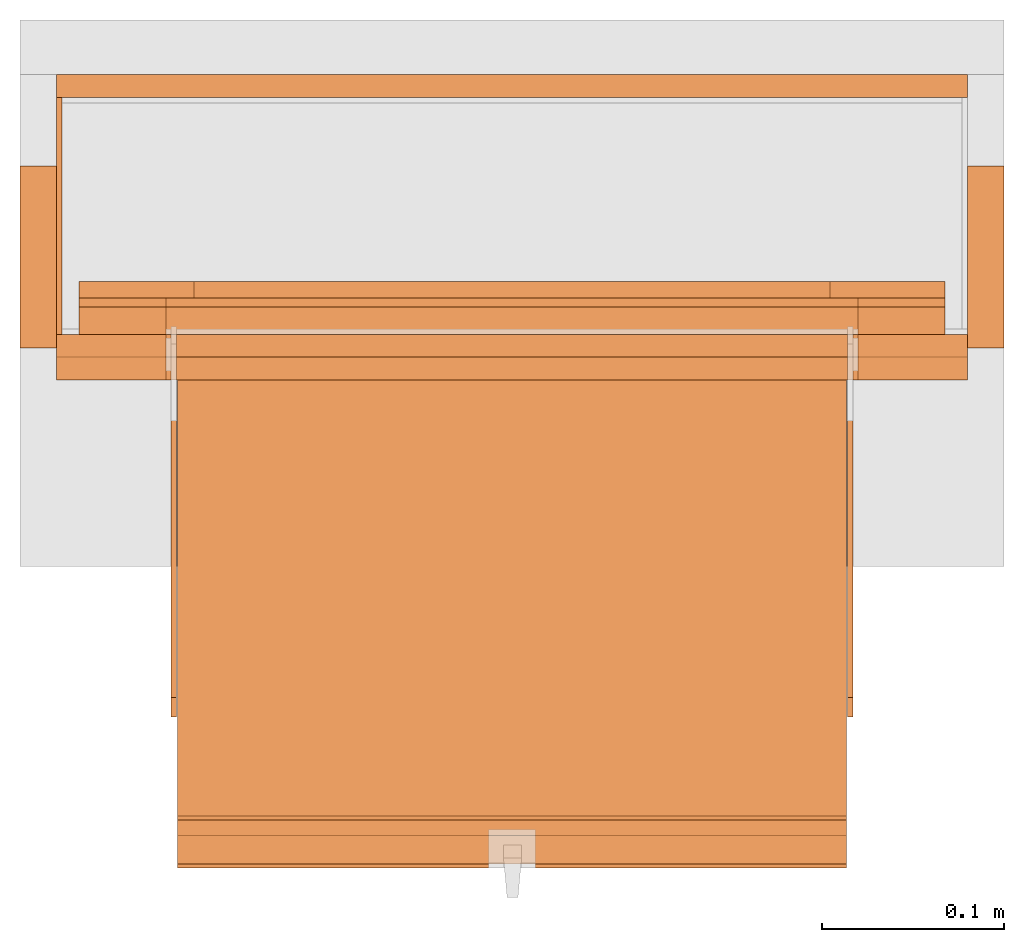
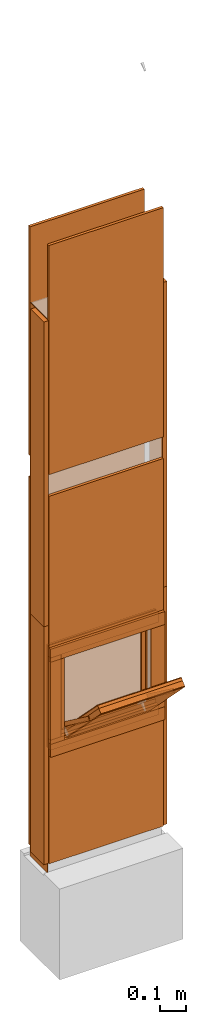
# One storey, part 1 of 4: 32 proxies, 1 opening.
"""IFC2X3 building model written with IfcOpenShell, lengths in metres."""

from ifc_helpers import new_model, entity, si_unit, converted_unit, derived_unit, money_unit, direction, frame, origin_with_axes, origin_2d_with_axis, place, context, subcontext, project, spatial, polyline, rectangle, outline, extrude, faceted_brep, source, transform, mapped, material, type_object, element, save


model = new_model("IFC2X3")

# Units and contexts
model_context = context("Model", 3, precision=1e-05, world=origin_with_axes(), true_north=direction((0.0, 1.0)))
plan_context = context("Plan", 3, precision=1e-05, world=origin_with_axes(), true_north=direction((0.0, 1.0)))
body_context = subcontext(model_context, "Body", "Model", "MODEL_VIEW")
ifc_project = project(units=[si_unit("LENGTHUNIT", "METRE"), si_unit("AREAUNIT", "SQUARE_METRE"), si_unit("VOLUMEUNIT", "CUBIC_METRE"), converted_unit("PLANEANGLEUNIT", "DEGREE", entity("IfcPlaneAngleMeasure", 0.0174532925199), si_unit("PLANEANGLEUNIT", "RADIAN"), dimensions=[0, 0, 0, 0, 0, 0, 0]), si_unit("SOLIDANGLEUNIT", "STERADIAN"), money_unit("CHF"), converted_unit("TIMEUNIT", "Year", entity("IfcTimeMeasure", 31556926.0), si_unit("TIMEUNIT", "SECOND"), dimensions=[0, 0, 1, 0, 0, 0, 0]), si_unit("MASSUNIT", "GRAM", prefix="KILO"), si_unit("THERMODYNAMICTEMPERATUREUNIT", "DEGREE_CELSIUS"), si_unit("LUMINOUSINTENSITYUNIT", "LUMEN"), si_unit("ENERGYUNIT", "JOULE", prefix="MEGA"), derived_unit("THERMALCONDUCTANCEUNIT", [(si_unit("POWERUNIT", "WATT"), 1), (si_unit("LENGTHUNIT", "METRE"), -1), (si_unit("THERMODYNAMICTEMPERATUREUNIT", "KELVIN"), -1)]), derived_unit("SPECIFICHEATCAPACITYUNIT", [(si_unit("ENERGYUNIT", "JOULE"), 1), (si_unit("MASSUNIT", "GRAM", prefix="KILO"), -1), (si_unit("THERMODYNAMICTEMPERATUREUNIT", "KELVIN"), -1)]), derived_unit("MASSDENSITYUNIT", [(si_unit("MASSUNIT", "GRAM", prefix="KILO"), 1), (si_unit("VOLUMEUNIT", "CUBIC_METRE"), -1)])], contexts=[model_context, plan_context])

# Site, building, storey
site_placement = place(None, origin_with_axes())
site = spatial("IfcSite", under=ifc_project, at=site_placement, CompositionType="ELEMENT")
building_placement = place(site_placement, origin_with_axes())
building = spatial("IfcBuilding", under=site, at=building_placement, CompositionType="ELEMENT")
storey_placement = place(building_placement, origin_with_axes())
storey = spatial("IfcBuildingStorey", under=building, at=storey_placement, Name="EG00", CompositionType="ELEMENT", Elevation=0.0)

# Proxies
ifc_material_1 = material(Name="Metall, Stahl")
building_element_proxy_type_1 = type_object("IfcBuildingElementProxyType", Name="Metall, Stahl 3", PredefinedType="NOTDEFINED")
proxy_1_placement = place(storey_placement, frame((1.55655524907, -8.09743070606, 0.0), z_axis=(0.0, 0.0, 1.0), x_axis=(0.0, -1.0, 0.0)))
element("IfcBuildingElementProxy", 1, at=proxy_1_placement, inside=storey, type_object=building_element_proxy_type_1, material=ifc_material_1, Name="Wand-005", context=body_context, shape_type="SweptSolid", body=[
    extrude(outline(polyline([(0.0, 0.0), (0.13, 0.0), (0.13, 0.003), (0.0, 0.003), (0.0, 0.0)])), origin_with_axes(), (0.0, 0.0, 1.0), 1.15),
])
proxy_2_placement = place(storey_placement, frame((1.55655524907, -8.09743070606, 1.15), z_axis=(0.0, 0.0, 1.0), x_axis=(0.0, -1.0, 0.0)))
element("IfcBuildingElementProxy", 2, at=proxy_2_placement, inside=storey, type_object=building_element_proxy_type_1, material=ifc_material_1, Name="Wand-005", context=body_context, shape_type="SweptSolid", body=[
    extrude(outline(polyline([(0.0, 0.0), (0.13, 0.0), (0.13, 0.003), (0.0, 0.003), (0.0, 0.0)])), origin_with_axes(), (0.0, 0.0, 1.0), 1.41),
])

# Proxy, opening
ifc_material_2 = material(Name="Gipsplatte horizontal")
building_element_proxy_type_2 = type_object("IfcBuildingElementProxyType", Name="Gipsplatte horizontal 13", PredefinedType="NOTDEFINED")
proxy_3_placement = place(storey_placement, frame((1.55655524907, -8.23993070606, 0.05), z_axis=(0.0, 0.0, 1.0), x_axis=(1.0, 0.0, 0.0)))
proxy_3 = element("IfcBuildingElementProxy", 3, at=proxy_3_placement, inside=storey, type_object=building_element_proxy_type_2, material=ifc_material_2, Name="Wand-004", context=body_context, shape_type="SweptSolid", body=[
    extrude(outline(polyline([(0.0, 0.0), (0.5, 0.0), (0.5, 0.0125), (0.0, 0.0125), (0.0, 0.0)])), origin_with_axes(), (0.0, 0.0, 1.0), 1.7),
])
opening_placement = place(proxy_3_placement, frame((-1.55655524907, 8.23993070606, -0.05), z_axis=(0.0, 0.0, 1.0), x_axis=(1.0, 0.0, 0.0)))
element("IfcOpeningElement", 4, at=opening_placement, cuts=proxy_3, Name="015", context=body_context, shape_type="SweptSolid", body=[
    extrude(rectangle(XDim=0.38, YDim=0.38, at=origin_2d_with_axis()), frame((1.80655524907, -8.25243070606, 0.8), z_axis=(0.0, -1.0, 0.0), x_axis=(1.0, 0.0, 0.0)), (0.0, 0.0, -1.0), 0.0375),
])

# Proxies
proxy_4_placement = place(storey_placement, frame((1.55655524907, -8.08493070606, 0.05), z_axis=(0.0, 0.0, 1.0), x_axis=(1.0, 0.0, 0.0)))
element("IfcBuildingElementProxy", 5, at=proxy_4_placement, inside=storey, type_object=building_element_proxy_type_2, material=ifc_material_2, Name="Wand-004", context=body_context, shape_type="SweptSolid", body=[
    extrude(outline(polyline([(0.0, -0.0125), (0.5, -0.0125), (0.5, 0.0), (0.0, 0.0), (0.0, -0.0125)])), origin_with_axes(), (0.0, 0.0, 1.0), 1.7),
])
proxy_5_placement = place(storey_placement, frame((1.55655524907, -8.23993070606, 1.85), z_axis=(0.0, 0.0, 1.0), x_axis=(1.0, 0.0, 0.0)))
element("IfcBuildingElementProxy", 6, at=proxy_5_placement, inside=storey, type_object=building_element_proxy_type_2, material=ifc_material_2, Name="Wand-004", context=body_context, shape_type="SweptSolid", body=[
    extrude(outline(polyline([(0.0, 0.0), (0.5, 0.0), (0.5, 0.0125), (0.0, 0.0125), (0.0, 0.0)])), origin_with_axes(), (0.0, 0.0, 1.0), 1.06),
])
proxy_6_placement = place(storey_placement, frame((1.55655524907, -8.08493070606, 1.85), z_axis=(0.0, 0.0, 1.0), x_axis=(1.0, 0.0, 0.0)))
element("IfcBuildingElementProxy", 7, at=proxy_6_placement, inside=storey, type_object=building_element_proxy_type_2, material=ifc_material_2, Name="Wand-004", context=body_context, shape_type="SweptSolid", body=[
    extrude(outline(polyline([(0.0, -0.0125), (0.5, -0.0125), (0.5, 0.0), (0.0, 0.0), (0.0, -0.0125)])), origin_with_axes(), (0.0, 0.0, 1.0), 1.06),
])
ifc_material_3 = material(Name="Holz")
building_element_proxy_type_3 = type_object("IfcBuildingElementProxyType", Name="Holz 20", PredefinedType="NOTDEFINED")
proxy_7_placement = place(storey_placement, frame((1.53655524907, -8.13493070606, 0.05), z_axis=(0.0, 0.0, 1.0), x_axis=(0.0, -1.0, 0.0)))
element("IfcBuildingElementProxy", 8, at=proxy_7_placement, inside=storey, type_object=building_element_proxy_type_3, material=ifc_material_3, Name="Wand-004", context=body_context, shape_type="SweptSolid", body=[
    extrude(outline(polyline([(0.0, 0.0), (0.1, 0.0), (0.1, 0.02), (0.0, 0.02), (0.0, 0.0)])), origin_with_axes(), (0.0, 0.0, 1.0), 1.1),
])
proxy_8_placement = place(storey_placement, frame((2.07655524907, -8.13493070606, 0.05), z_axis=(0.0, 0.0, 1.0), x_axis=(0.0, -1.0, 0.0)))
element("IfcBuildingElementProxy", 9, at=proxy_8_placement, inside=storey, type_object=building_element_proxy_type_3, material=ifc_material_3, Name="Wand-003", context=body_context, shape_type="SweptSolid", body=[
    extrude(outline(polyline([(0.0, -0.02), (0.1, -0.02), (0.1, 0.0), (0.0, 0.0), (0.0, -0.02)])), origin_with_axes(), (0.0, 0.0, 1.0), 1.1),
])
proxy_9_placement = place(storey_placement, frame((1.53655524907, -8.13493070606, 1.15), z_axis=(0.0, 0.0, 1.0), x_axis=(0.0, -1.0, 0.0)))
element("IfcBuildingElementProxy", 10, at=proxy_9_placement, inside=storey, type_object=building_element_proxy_type_3, material=ifc_material_3, Name="Wand-004", context=body_context, shape_type="SweptSolid", body=[
    extrude(outline(polyline([(0.0, 0.0), (0.1, 0.0), (0.1, 0.02), (0.0, 0.02), (0.0, 0.0)])), origin_with_axes(), (0.0, 0.0, 1.0), 1.41),
])
proxy_10_placement = place(storey_placement, frame((2.07655524907, -8.13493070606, 1.15), z_axis=(0.0, 0.0, 1.0), x_axis=(0.0, -1.0, 0.0)))
element("IfcBuildingElementProxy", 11, at=proxy_10_placement, inside=storey, type_object=building_element_proxy_type_3, material=ifc_material_3, Name="Wand-003", context=body_context, shape_type="SweptSolid", body=[
    extrude(outline(polyline([(0.0, -0.02), (0.1, -0.02), (0.1, 0.0), (0.0, 0.0), (0.0, -0.02)])), origin_with_axes(), (0.0, 0.0, 1.0), 1.41),
])
building_element_proxy_type_4 = type_object("IfcBuildingElementProxyType", Name="Holz 25", PredefinedType="NOTDEFINED")
for number, where, z_axis, x_axis, name in (
    (12, (2.05655524907, -8.22743070606, 0.99), (0.0, 0.0, 1.0), (-1.0, 0.0, 0.0), "Wand-004"),
    (13, (2.05655524907, -8.22743070606, 0.55), (0.0, 0.0, 1.0), (-1.0, 0.0, 0.0), "Wand-004"),
):
    element("IfcBuildingElementProxy", number, at=place(storey_placement, frame(where, z_axis=z_axis, x_axis=x_axis)), inside=storey, type_object=building_element_proxy_type_4, material=ifc_material_3, Name=name, context=body_context, shape_type="SweptSolid", body=[
        extrude(outline(polyline([(0.0, 0.0), (0.5, 0.0), (0.5, 0.025), (0.0, 0.025), (0.0, 0.0)])), origin_with_axes(), (0.0, 0.0, 1.0), 0.06),
    ])
for number, where, z_axis, x_axis, name in (
    (14, (1.99655524907, -8.25243070606, 0.61), (0.0, 0.0, 1.0), (1.0, 0.0, 0.0), "Wand-004"),
    (15, (1.55655524907, -8.25243070606, 0.61), (0.0, 0.0, 1.0), (1.0, 0.0, 0.0), "Wand-004"),
):
    element("IfcBuildingElementProxy", number, at=place(storey_placement, frame(where, z_axis=z_axis, x_axis=x_axis)), inside=storey, type_object=building_element_proxy_type_4, material=ifc_material_3, Name=name, context=body_context, shape_type="SweptSolid", body=[
        extrude(outline(polyline([(0.0, 0.0), (0.06, 0.0), (0.06, 0.025), (0.0, 0.025), (0.0, 0.0)])), origin_with_axes(), (0.0, 0.0, 1.0), 0.38),
    ])
building_element_proxy_type_5 = type_object("IfcBuildingElementProxyType", Name="Holz 15", PredefinedType="NOTDEFINED")
for number, where, z_axis, x_axis, name in (
    (16, (2.04405524907, -8.21243070606, 0.99), (0.0, 0.0, 1.0), (-1.0, 0.0, 0.0), "Wand-004"),
    (17, (2.04405524907, -8.21243070606, 0.5625), (0.0, 0.0, 1.0), (-1.0, 0.0, 0.0), "Wand-004"),
):
    element("IfcBuildingElementProxy", number, at=place(storey_placement, frame(where, z_axis=z_axis, x_axis=x_axis)), inside=storey, type_object=building_element_proxy_type_5, material=ifc_material_3, Name=name, context=body_context, shape_type="SweptSolid", body=[
        extrude(outline(polyline([(0.0, 0.0), (0.475, 0.0), (0.475, 0.015), (0.0, 0.015), (0.0, 0.0)])), origin_with_axes(), (0.0, 0.0, 1.0), 0.0475),
    ])
for number, where, z_axis, x_axis, name in (
    (18, (1.99655524907, -8.22743070606, 0.61), (0.0, 0.0, 1.0), (1.0, 0.0, 0.0), "Wand-004"),
    (19, (1.56905524907, -8.22743070606, 0.61), (0.0, 0.0, 1.0), (1.0, 0.0, 0.0), "Wand-004"),
):
    element("IfcBuildingElementProxy", number, at=place(storey_placement, frame(where, z_axis=z_axis, x_axis=x_axis)), inside=storey, type_object=building_element_proxy_type_5, material=ifc_material_3, Name=name, context=body_context, shape_type="SweptSolid", body=[
        extrude(outline(polyline([(0.0, 0.0), (0.0475, 0.0), (0.0475, 0.015), (0.0, 0.015), (0.0, 0.0)])), origin_with_axes(), (0.0, 0.0, 1.0), 0.38),
    ])
building_element_proxy_type_6 = type_object("IfcBuildingElementProxyType", Name="Holz 5", PredefinedType="NOTDEFINED")
for number, where, z_axis, x_axis, name in (
    (20, (2.04405524907, -8.21243070606, 1.0), (0.0, 0.0, 1.0), (-1.0, 0.0, 0.0), "Wand-004"),
    (21, (2.04405524907, -8.21243070606, 0.5625), (0.0, 0.0, 1.0), (-1.0, 0.0, 0.0), "Wand-004"),
):
    element("IfcBuildingElementProxy", number, at=place(storey_placement, frame(where, z_axis=z_axis, x_axis=x_axis)), inside=storey, type_object=building_element_proxy_type_6, material=ifc_material_3, Name=name, context=body_context, shape_type="SweptSolid", body=[
        extrude(outline(polyline([(0.0, -0.005), (0.475, -0.005), (0.475, 0.0), (0.0, 0.0), (0.0, -0.005)])), origin_with_axes(), (0.0, 0.0, 1.0), 0.0375),
    ])
for number, where, z_axis, x_axis, name in (
    (22, (1.99655524907, -8.21243070606, 0.6), (0.0, 0.0, 1.0), (1.0, 0.0, 0.0), "Wand-004"),
    (23, (1.56905524907, -8.21243070606, 0.6), (0.0, 0.0, 1.0), (1.0, 0.0, 0.0), "Wand-004"),
):
    element("IfcBuildingElementProxy", number, at=place(storey_placement, frame(where, z_axis=z_axis, x_axis=x_axis)), inside=storey, type_object=building_element_proxy_type_6, material=ifc_material_3, Name=name, context=body_context, shape_type="SweptSolid", body=[
        extrude(outline(polyline([(0.0, 0.0), (0.0475, 0.0), (0.0475, 0.005), (0.0, 0.005), (0.0, 0.0)])), origin_with_axes(), (0.0, 0.0, 1.0), 0.4),
    ])
building_element_proxy_type_7 = type_object("IfcBuildingElementProxyType", Name="Holz 9", PredefinedType="NOTDEFINED")
for number, where, z_axis, x_axis, name in (
    (24, (2.04405524907, -8.20743070606, 0.975), (0.0, 0.0, 1.0), (-1.0, 0.0, 0.0), "Wand-004"),
    (25, (2.04405524907, -8.20743070606, 0.5625), (0.0, 0.0, 1.0), (-1.0, 0.0, 0.0), "Wand-004"),
):
    element("IfcBuildingElementProxy", number, at=place(storey_placement, frame(where, z_axis=z_axis, x_axis=x_axis)), inside=storey, type_object=building_element_proxy_type_7, material=ifc_material_3, Name=name, context=body_context, shape_type="SweptSolid", body=[
        extrude(outline(polyline([(0.0, -0.009), (0.475, -0.009), (0.475, 0.0), (0.0, 0.0), (0.0, -0.009)])), origin_with_axes(), (0.0, 0.0, 1.0), 0.0625),
    ])
for number, where, z_axis, x_axis, name in (
    (26, (1.98105524907, -8.20743070606, 0.625), (0.0, 0.0, 1.0), (1.0, 0.0, 0.0), "Wand-004"),
    (27, (1.56905524907, -8.20743070606, 0.625), (0.0, 0.0, 1.0), (1.0, 0.0, 0.0), "Wand-004"),
):
    element("IfcBuildingElementProxy", number, at=place(storey_placement, frame(where, z_axis=z_axis, x_axis=x_axis)), inside=storey, type_object=building_element_proxy_type_7, material=ifc_material_3, Name=name, context=body_context, shape_type="SweptSolid", body=[
        extrude(outline(polyline([(0.0, 0.0), (0.063, 0.0), (0.063, 0.009), (0.0, 0.009), (0.0, 0.0)])), origin_with_axes(), (0.0, 0.0, 1.0), 0.35),
    ])
ifc_material_4 = material(Name="Metall, Aluminium")
building_element_proxy_type_8 = type_object("IfcBuildingElementProxyType", Name="Metall, Aluminium", PredefinedType="NOTDEFINED")
shared_shape_1 = source(origin_with_axes(), body_context, "Body", "Brep", [
    faceted_brep([(16.1060766769, -3.29167330347, 0.736478855326), (16.1060766769, -3.65867330347, 0.736478855326), (16.1060766769, -3.65867330347, 1.10947885533), (16.1060766769, -3.29167330347, 1.10947885533), (16.1091136769, -3.29167330347, 0.736478855326), (16.1091136769, -3.65867330347, 0.736478855326), (16.1091136769, -3.65867330347, 1.10947885533), (16.1091136769, -3.29167330347, 1.10947885533)], [[[0, 1, 2, 3]], [[1, 0, 4, 5]], [[2, 1, 5, 6]], [[3, 2, 6, 7]], [[0, 3, 7, 4]], [[5, 4, 7, 6]]]),
])
proxy_11_placement = place(storey_placement, frame((5.28172855254, 3.75690888182, 11.375802015), z_axis=(0.0, -0.700249431637, 0.713898265506), x_axis=(0.0, -0.713898265506, -0.700249431637)))
element("IfcBuildingElementProxy", 28, at=proxy_11_placement, inside=storey, type_object=building_element_proxy_type_8, material=ifc_material_4, Name="Wand-004", context=body_context, shape_type="MappedRepresentation", body=[
    mapped(shared_shape_1, transform((0.0, 0.0, 0.0))),
])
building_element_proxy_type_9 = type_object("IfcBuildingElementProxyType", Name="Holz", PredefinedType="NOTDEFINED")
shared_shape_2 = source(origin_with_axes(), body_context, "Body", "Brep", [
    faceted_brep([(16.0840766769, -3.65867330347, 1.10947885533), (16.0840766769, -3.29167330347, 1.10947885533), (16.0840766769, -3.29167330347, 0.736478855326), (16.0840766769, -3.65867330347, 0.736478855326), (16.1060766769, -3.65867330347, 1.10947885533), (16.1060766769, -3.29167330347, 1.10947885533), (16.1060766769, -3.29167330347, 0.736478855326), (16.1060766769, -3.65867330347, 0.736478855326)], [[[0, 1, 2, 3]], [[1, 0, 4, 5]], [[2, 1, 5, 6]], [[3, 2, 6, 7]], [[0, 3, 7, 4]], [[4, 7, 6, 5]]]),
])
proxy_12_placement = place(storey_placement, frame((5.28172855254, 3.75690888182, 11.375802015), z_axis=(0.0, -0.700249431637, 0.713898265506), x_axis=(0.0, -0.713898265506, -0.700249431637)))
element("IfcBuildingElementProxy", 29, at=proxy_12_placement, inside=storey, type_object=building_element_proxy_type_9, material=ifc_material_3, Name="Wand-004", context=body_context, shape_type="MappedRepresentation", body=[
    mapped(shared_shape_2, transform((0.0, 0.0, 0.0))),
])
building_element_proxy_type_10 = type_object("IfcBuildingElementProxyType", Name="Gipsplatte horizontal", PredefinedType="NOTDEFINED")
shared_shape_3 = source(origin_with_axes(), body_context, "Body", "Brep", [
    faceted_brep([(16.0720766769, -3.65867330347, 1.10947885533), (16.0720766769, -3.29167330347, 1.10947885533), (16.0720766769, -3.29167330347, 0.736478855326), (16.0720766769, -3.65867330347, 0.736478855326), (16.0840766769, -3.65867330347, 1.10947885533), (16.0840766769, -3.29167330347, 1.10947885533), (16.0840766769, -3.29167330347, 0.736478855326), (16.0840766769, -3.65867330347, 0.736478855326)], [[[0, 1, 2, 3]], [[1, 0, 4, 5]], [[2, 1, 5, 6]], [[3, 2, 6, 7]], [[0, 3, 7, 4]], [[4, 7, 6, 5]]]),
])
proxy_13_placement = place(storey_placement, frame((5.28172855254, 3.75690888182, 11.375802015), z_axis=(0.0, -0.700249431637, 0.713898265506), x_axis=(0.0, -0.713898265506, -0.700249431637)))
element("IfcBuildingElementProxy", 30, at=proxy_13_placement, inside=storey, type_object=building_element_proxy_type_10, material=ifc_material_2, Name="Wand-004", context=body_context, shape_type="MappedRepresentation", body=[
    mapped(shared_shape_3, transform((0.0, 0.0, 0.0))),
])
shared_shape_4 = source(origin_with_axes(), body_context, "Body", "Brep", [
    faceted_brep([(16.0690396769, -3.29167330347, 0.736478855326), (16.0690396769, -3.65867330347, 0.736478855326), (16.0690396769, -3.65867330347, 1.10947885533), (16.0690396769, -3.29167330347, 1.10947885533), (16.0720766769, -3.29167330347, 0.736478855326), (16.0720766769, -3.65867330347, 0.736478855326), (16.0720766769, -3.65867330347, 1.10947885533), (16.0720766769, -3.29167330347, 1.10947885533)], [[[0, 1, 2, 3]], [[1, 0, 4, 5]], [[2, 1, 5, 6]], [[3, 2, 6, 7]], [[0, 3, 7, 4]], [[5, 4, 7, 6]]]),
])
proxy_14_placement = place(storey_placement, frame((5.28172855254, 3.75690888182, 11.375802015), z_axis=(0.0, -0.700249431637, 0.713898265506), x_axis=(0.0, -0.713898265506, -0.700249431637)))
element("IfcBuildingElementProxy", 31, at=proxy_14_placement, inside=storey, type_object=building_element_proxy_type_8, material=ifc_material_4, Name="Wand-004", context=body_context, shape_type="MappedRepresentation", body=[
    mapped(shared_shape_4, transform((0.0, 0.0, 0.0))),
])
shared_shape_5 = source(origin_with_axes(), body_context, "Body", "Brep", [
    faceted_brep([(16.1152851057, -3.58730556817, 0.89), (16.1152851057, -3.59030556817, 0.89), (16.1152851057, -3.59030556817, 1.14), (16.1152851057, -3.58730556817, 1.14), (16.1332851057, -3.59030556817, 0.89), (16.1332851057, -3.58730556817, 0.89), (16.1332851057, -3.59030556817, 1.14), (16.1332851057, -3.58730556817, 1.14)], [[[0, 1, 2, 3]], [[4, 1, 0, 5]], [[1, 4, 6, 2]], [[2, 6, 7, 3]], [[0, 3, 7, 5]], [[4, 5, 7, 6]]]),
])
for number, where, z_axis, x_axis, name in (
    (32, (5.20986081724, 2.09768488745, 13.081222354), (0.0, -0.80277012101, 0.596288632135), (0.0, -0.596288632135, -0.80277012101), "Wand-004"),
    (33, (5.58086081724, 2.09768488745, 13.081222354), (0.0, -0.80277012101, 0.596288632135), (0.0, -0.596288632135, -0.80277012101), "Wand-004"),
):
    element("IfcBuildingElementProxy", number, at=place(storey_placement, frame(where, z_axis=z_axis, x_axis=x_axis)), inside=storey, type_object=building_element_proxy_type_8, material=ifc_material_4, Name=name, context=body_context, shape_type="MappedRepresentation", body=[
        mapped(shared_shape_5, transform((0.0, 0.0, 0.0))),
    ])

save(model, "model.ifc")
